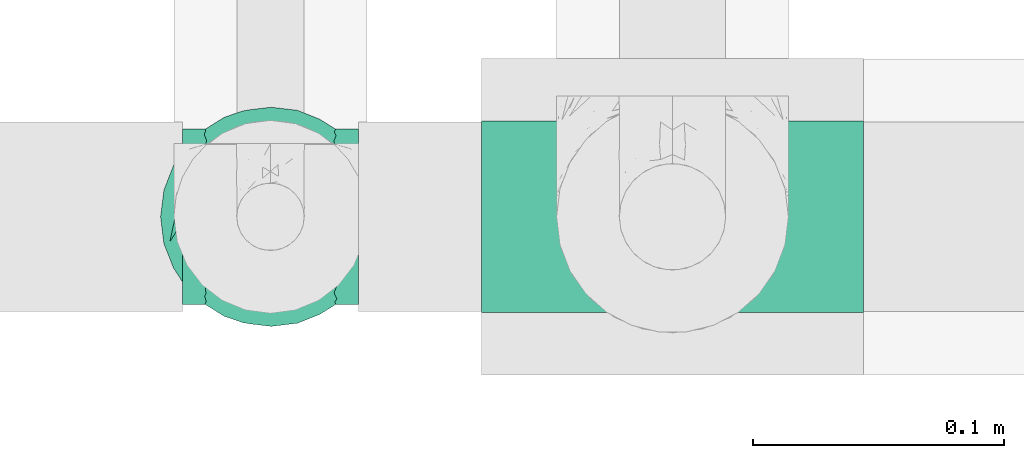
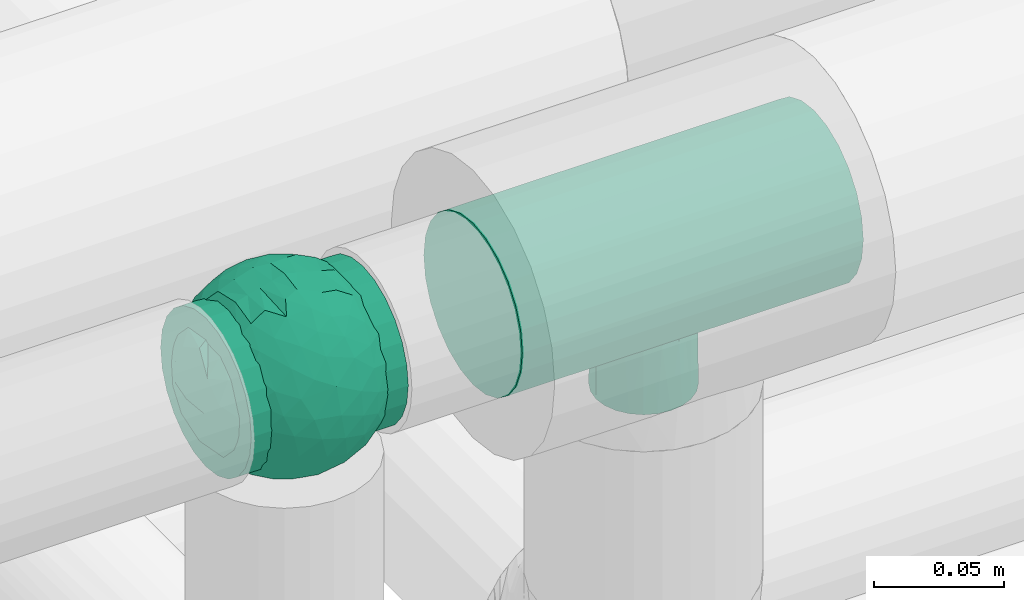
# One storey, part 690 of 827: 2 flow fittings.
"""IFC2X3 building model written with IfcOpenShell, lengths in millimetres."""

from ifc_helpers import new_model, entity, si_unit, converted_unit, derived_unit, direction, frame, origin, place, context, subcontext, project, spatial, faceted_brep, source, transform, mapped, material, material_list, type_object, type_shapes, element, save


model = new_model("IFC2X3")

# Units and contexts
model_context = context("Model", 3, precision=0.01, world=origin(), true_north=direction((6.12303176911189e-17, 1.0)))
body_context = subcontext(model_context, "Body", "Model", "MODEL_VIEW")
ifc_project = project(units=[si_unit("LENGTHUNIT", "METRE", prefix="MILLI"), si_unit("AREAUNIT", "SQUARE_METRE"), si_unit("VOLUMEUNIT", "CUBIC_METRE"), converted_unit("PLANEANGLEUNIT", "DEGREE", entity("IfcRatioMeasure", 0.0174532925199433), si_unit("PLANEANGLEUNIT", "RADIAN"), dimensions=[0, 0, 0, 0, 0, 0, 0]), si_unit("MASSUNIT", "GRAM", prefix="KILO"), derived_unit("MASSDENSITYUNIT", [(si_unit("MASSUNIT", "GRAM", prefix="KILO"), 1), (si_unit("LENGTHUNIT", "METRE"), -3)]), derived_unit("MOMENTOFINERTIAUNIT", [(si_unit("LENGTHUNIT", "METRE"), 4)]), si_unit("TIMEUNIT", "SECOND"), si_unit("FREQUENCYUNIT", "HERTZ"), si_unit("THERMODYNAMICTEMPERATUREUNIT", "DEGREE_CELSIUS"), derived_unit("THERMALTRANSMITTANCEUNIT", [(si_unit("MASSUNIT", "GRAM", prefix="KILO"), 1), (si_unit("THERMODYNAMICTEMPERATUREUNIT", "KELVIN"), -1), (si_unit("TIMEUNIT", "SECOND"), -3)]), derived_unit("VOLUMETRICFLOWRATEUNIT", [(si_unit("LENGTHUNIT", "METRE"), 3), (si_unit("TIMEUNIT", "SECOND"), -1)]), derived_unit("MASSFLOWRATEUNIT", [(si_unit("MASSUNIT", "GRAM", prefix="KILO"), 1), (si_unit("TIMEUNIT", "SECOND"), -1)]), derived_unit("ROTATIONALFREQUENCYUNIT", [(si_unit("TIMEUNIT", "SECOND"), -1)]), si_unit("ELECTRICCURRENTUNIT", "AMPERE"), si_unit("ELECTRICVOLTAGEUNIT", "VOLT"), si_unit("POWERUNIT", "WATT"), si_unit("FORCEUNIT", "NEWTON", prefix="KILO"), si_unit("ILLUMINANCEUNIT", "LUX"), si_unit("LUMINOUSFLUXUNIT", "LUMEN"), si_unit("LUMINOUSINTENSITYUNIT", "CANDELA"), derived_unit("USERDEFINED", [(si_unit("MASSUNIT", "GRAM", prefix="KILO"), -1), (si_unit("LENGTHUNIT", "METRE"), -2), (si_unit("TIMEUNIT", "SECOND"), 3), (si_unit("LUMINOUSFLUXUNIT", "LUMEN"), 1)]), derived_unit("LINEARVELOCITYUNIT", [(si_unit("LENGTHUNIT", "METRE"), 1), (si_unit("TIMEUNIT", "SECOND"), -1)]), si_unit("PRESSUREUNIT", "PASCAL"), derived_unit("USERDEFINED", [(si_unit("LENGTHUNIT", "METRE"), -2), (si_unit("MASSUNIT", "GRAM", prefix="KILO"), 1), (si_unit("TIMEUNIT", "SECOND"), -2)]), derived_unit("LINEARFORCEUNIT", [(si_unit("MASSUNIT", "GRAM", prefix="KILO"), 1), (si_unit("LENGTHUNIT", "METRE"), 1), (si_unit("TIMEUNIT", "SECOND"), -2), (si_unit("LENGTHUNIT", "METRE"), -1)]), derived_unit("PLANARFORCEUNIT", [(si_unit("MASSUNIT", "GRAM", prefix="KILO"), 1), (si_unit("LENGTHUNIT", "METRE"), 1), (si_unit("TIMEUNIT", "SECOND"), -2), (si_unit("LENGTHUNIT", "METRE"), -2)])], contexts=[model_context])

# Site, building, storey
site_placement = place(None, origin())
site = spatial("IfcSite", under=ifc_project, at=site_placement, CompositionType="ELEMENT")
building_placement = place(site_placement, origin())
building = spatial("IfcBuilding", under=site, at=building_placement, CompositionType="ELEMENT")
storey_placement = place(building_placement, frame((0.0, 0.0, 28200.0)))
storey = spatial("IfcBuildingStorey", under=building, at=storey_placement, Name="08", CompositionType="ELEMENT", Elevation=28200.0)

# Flow fittings
ifc_material_1 = material()
ifc_material_2 = material(Name="ADSK_")
ifc_material_list = material_list([ifc_material_1, ifc_material_2])
pipe_fitting_type_1 = type_object("IfcPipeFittingType", Name="ADSK_1", PredefinedType="NOTDEFINED", material=ifc_material_list)
shared_shape_1 = source(origin(), body_context, "Body", "Brep", [
    faceted_brep([(-35.0, 9.06, -33.81), (-35.0, 0.0, -35.0), (-35.0, -9.06, -33.81), (-35.0, -17.5, -30.31), (-35.0, -24.75, -24.75), (-35.0, -30.31, -17.5), (-35.0, -33.81, -9.06), (-35.0, -34.4, -4.53), (-35.0, -35.0, 0.0), (-35.0, -34.4, 4.53), (-35.0, -33.81, 9.06), (-35.0, -30.31, 17.5), (-35.0, -24.75, 24.75), (-35.0, -17.5, 30.31), (-35.0, -9.06, 33.81), (-35.0, 0.0, 35.0), (-35.0, 9.06, 33.81), (-35.0, 17.5, 30.31), (-35.0, 24.75, 24.75), (-35.0, 30.31, 17.5), (-35.0, 33.81, 9.06), (-35.0, 35.0, 0.0), (-35.0, 33.81, -9.06), (-35.0, 30.31, -17.5), (-35.0, 24.75, -24.75), (-35.0, 17.5, -30.31), (35.0, 33.81, -9.06), (35.0, 35.0, 0.0), (35.0, 33.81, 9.06), (35.0, 30.31, 17.5), (35.0, 24.75, 24.75), (35.0, 17.5, 30.31), (35.0, 9.06, 33.81), (35.0, 0.0, 35.0), (35.0, -9.06, 33.81), (35.0, -17.5, 30.31), (35.0, -24.75, 24.75), (35.0, -30.31, 17.5), (35.0, -33.81, 9.06), (35.0, -34.4, 4.53), (35.0, -35.0, 0.0), (35.0, -34.4, -4.53), (35.0, -33.81, -9.06), (35.0, -30.31, -17.5), (35.0, -24.75, -24.75), (35.0, -17.5, -30.31), (35.0, -9.06, -33.81), (35.0, 0.0, -35.0), (35.0, 9.06, -33.81), (35.0, 17.5, -30.31), (35.0, 24.75, -24.75), (35.0, 30.31, -17.5), (12.5, -35.0, 0.0), (11.74, -34.73, 4.3), (9.57, -34.06, 8.04), (2.19, -32.76, 12.31), (6.27, -33.29, 10.81), (-9.57, -34.06, 8.04), (-11.74, -34.73, 4.3), (-12.5, -35.0, 0.0), (-6.27, -33.29, 10.81), (-2.19, -32.76, 12.31), (-11.74, -34.73, -4.3), (9.57, -34.06, -8.04), (11.74, -34.73, -4.3), (6.27, -33.29, -10.81), (2.19, -32.76, -12.31), (-2.19, -32.76, -12.31), (-6.27, -33.29, -10.81), (-9.57, -34.06, -8.04), (0.0, -40.0, -12.5), (3.24, -40.0, -12.07), (6.25, -40.0, -10.83), (8.84, -40.0, -8.84), (10.83, -40.0, -6.25), (12.07, -40.0, -3.24), (12.5, -40.0, 0.0), (12.07, -40.0, 3.24), (10.83, -40.0, 6.25), (8.84, -40.0, 8.84), (6.25, -40.0, 10.83), (3.24, -40.0, 12.07), (0.0, -40.0, 12.5), (-3.24, -40.0, 12.07), (-6.25, -40.0, 10.83), (-8.84, -40.0, 8.84), (-10.83, -40.0, 6.25), (-12.07, -40.0, 3.24), (-12.5, -40.0, 0.0), (-12.07, -40.0, -3.24), (-10.83, -40.0, -6.25), (-8.84, -40.0, -8.84), (-6.25, -40.0, -10.83), (-3.24, -40.0, -12.07)], [[[0, 1, 2, 3, 4, 5, 6, 7, 8, 9, 10, 11, 12, 13, 14, 15, 16, 17, 18, 19, 20, 21, 22, 23, 24, 25]], [[26, 27, 28, 29, 30, 31, 32, 33, 34, 35, 36, 37, 38, 39, 40, 41, 42, 43, 44, 45, 46, 47, 48, 49, 50, 51]], [[52, 40, 53]], [[54, 53, 39]], [[39, 38, 54]], [[55, 37, 11]], [[38, 55, 56]], [[55, 38, 37]], [[38, 56, 54]], [[37, 36, 12, 11]], [[57, 9, 58]], [[8, 58, 9]], [[8, 59, 58]], [[57, 10, 9]], [[60, 61, 10]], [[61, 11, 10]], [[61, 55, 11]], [[60, 10, 57]], [[53, 40, 39]], [[36, 35, 13, 12]], [[15, 14, 34, 33]], [[14, 13, 35, 34]], [[16, 15, 33, 32]], [[29, 28, 20, 19]], [[18, 17, 31, 30]], [[19, 18, 30, 29]], [[32, 31, 17, 16]], [[21, 20, 28, 27]], [[21, 27, 26, 22]], [[22, 26, 51, 23]], [[24, 23, 51, 50]], [[2, 1, 47, 46]], [[0, 25, 49, 48]], [[47, 1, 0, 48]], [[49, 25, 24, 50]], [[45, 3, 2, 46]], [[62, 8, 7]], [[45, 44, 4, 3]], [[5, 4, 44, 43]], [[63, 41, 64]], [[42, 65, 66]], [[66, 43, 42]], [[5, 43, 66]], [[41, 40, 64]], [[63, 42, 41]], [[52, 64, 40]], [[42, 63, 65]], [[5, 67, 6]], [[67, 68, 6]], [[5, 66, 67]], [[62, 7, 69]], [[7, 6, 69]], [[8, 62, 59]], [[69, 6, 68]], [[70, 71, 72, 73, 74, 75, 76, 77, 78, 79, 80, 81, 82, 83, 84, 85, 86, 87, 88, 89, 90, 91, 92, 93]], [[59, 88, 87]], [[58, 86, 85]], [[87, 86, 59]], [[85, 84, 58]], [[59, 86, 58]], [[57, 58, 83]], [[61, 60, 56]], [[57, 54, 60]], [[83, 82, 57]], [[84, 83, 58]], [[54, 82, 81]], [[80, 53, 81]], [[53, 79, 78]], [[80, 79, 53]], [[52, 78, 77]], [[56, 55, 61]], [[54, 56, 60]], [[78, 52, 53]], [[53, 54, 81]], [[52, 77, 76]], [[57, 82, 54]], [[76, 75, 52]], [[73, 72, 64]], [[74, 73, 64]], [[75, 74, 52]], [[52, 74, 64]], [[63, 64, 71]], [[66, 65, 67]], [[63, 68, 65]], [[71, 70, 63]], [[72, 71, 64]], [[93, 92, 62]], [[70, 93, 69]], [[90, 89, 59]], [[91, 90, 62]], [[92, 91, 62]], [[68, 67, 65]], [[69, 68, 63]], [[90, 59, 62]], [[62, 69, 93]], [[59, 89, 88]], [[63, 70, 69]]]),
    faceted_brep([(40.99, -9.07, -12.32), (38.16, -18.39, -10.93), (36.84, -12.08, -20.28), (-10.94, -40.82, 0.0), (-15.58, -39.11, -11.91), (-9.92, -38.23, -18.83), (-21.96, -6.8, -37.22), (-28.12, 0.0, -33.51), (-18.49, 2.46, -39.57), (7.18, -35.67, -24.29), (15.31, -38.73, -13.42), (8.77, -40.44, -14.19), (42.03, 0.03, -12.13), (40.09, 14.36, -10.04), (40.82, 10.94, 0.0), (23.53, 13.3, -34.4), (12.46, 12.13, -40.15), (17.01, 22.71, -33.3), (33.97, -22.81, -15.49), (33.89, -25.88, 0.0), (-17.56, -33.17, -22.48), (-9.73, -30.72, -29.59), (32.82, 10.98, -26.77), (35.78, 20.39, -14.77), (39.41, 6.34, -17.91), (-6.73, 41.38, -12.52), (-10.94, 40.82, 0.0), (-5.47, 42.28, 0.0), (-39.41, -6.34, -17.91), (-34.66, -3.23, -26.5), (-35.7, -17.2, -18.54), (-40.84, 8.27, -13.33), (-40.82, 10.94, 0.0), (-39.08, 16.52, -10.68), (26.2, -22.53, -26.83), (19.73, -22.3, -32.05), (18.8, -14.77, -36.64), (-40.09, -14.36, -10.04), (-42.42, 0.57, -10.68), (-38.6, 2.92, -20.39), (-33.71, 5.81, -27.28), (-35.11, 22.36, -13.46), (-36.84, 12.08, -20.28), (-7.82, 5.75, -42.66), (-4.31, 16.52, -40.28), (2.55, 8.59, -42.82), (-28.09, 28.94, -16.95), (-22.22, 29.25, -23.76), (-22.19, 21.47, -31.0), (-15.79, 13.61, -38.47), (-25.69, 11.2, -33.6), (-34.44, -24.53, -11.23), (-28.84, -30.19, -13.07), (-29.88, -29.88, 0.0), (-30.32, -11.15, -29.5), (-30.71, 19.03, -24.67), (-29.88, 29.88, 0.0), (-21.87, 37.89, 0.0), (-12.26, 23.64, -34.71), (-24.05, -29.02, -22.21), (-22.18, -35.56, -12.55), (-15.83, -24.35, -32.72), (5.66, 19.83, -38.58), (10.82, 1.29, -42.37), (19.64, -4.55, -38.83), (10.45, -9.76, -41.35), (5.47, 42.28, 0.0), (10.94, 40.82, 0.0), (8.45, 41.16, -12.17), (21.88, 37.89, 0.0), (28.41, 30.93, -12.26), (22.11, 34.85, -14.53), (27.19, -11.68, -32.22), (-10.91, -4.19, -42.16), (-0.38, -15.53, -40.9), (-15.09, -13.39, -38.82), (38.72, -2.98, -20.15), (33.54, -5.5, -27.55), (35.26, 2.9, -25.74), (0.73, -39.14, -19.53), (-37.89, 21.87, 0.0), (-33.89, 25.88, 0.0), (14.01, 38.49, -15.38), (15.74, 32.52, -24.68), (5.47, -42.28, 0.0), (-0.33, -42.57, -10.07), (8.2, 28.42, -32.24), (7.65, 35.47, -24.45), (-22.26, 35.43, -12.78), (-16.78, 34.37, -21.23), (-1.21, 33.73, -27.84), (0.73, 39.14, -19.53), (16.41, 39.35, 0.0), (-6.64, -41.44, -12.35), (10.46, -22.3, -36.16), (-1.67, -26.4, -34.84), (-1.24, -33.73, -27.84), (16.41, -39.35, 0.0), (22.1, -34.75, -14.77), (21.88, -37.89, 0.0), (-16.41, 39.35, 0.0), (-15.58, 39.13, -11.84), (-8.82, 37.78, -20.23), (-9.77, 32.04, -28.15), (-23.41, -16.43, -33.11), (0.25, -3.35, -43.62), (39.35, -16.41, 0.0), (28.12, 0.0, -33.51), (29.88, -29.88, 0.0), (28.41, -30.93, -12.26), (32.42, -13.09, -26.29), (-1.67, 26.4, -34.84), (22.5, 28.09, -24.87), (28.62, 22.02, -24.7), (19.21, 5.23, -38.96), (29.88, 29.88, 0.0), (33.89, 25.88, 0.0), (37.89, 21.87, 0.0), (-0.33, 42.57, -10.07), (0.0, 43.75, 0.0), (-8.6, -19.79, -38.06), (9.0, -29.66, -30.88), (15.05, -33.47, -23.82), (21.12, -28.8, -25.27), (-28.7, -22.0, -24.62), (-33.89, -25.88, 0.0), (-43.75, 0.0, 0.0), (-40.82, -10.94, 0.0), (-37.89, -21.88, 0.0), (0.0, -43.75, 0.0), (-5.47, -42.28, 0.0), (-21.87, -37.89, 0.0), (-16.41, -39.35, 0.0), (10.94, -40.82, 0.0), (40.82, -10.94, 0.0), (39.35, 16.41, 0.0), (43.75, 0.0, 0.0), (37.89, -21.88, 0.0), (-35.11, -22.36, 13.46), (-36.84, -12.08, 20.28), (-39.08, -16.52, 10.68), (-15.58, 39.11, 11.91), (-9.92, 38.23, 18.83), (-21.96, 6.8, 37.22), (-28.12, 0.0, 33.51), (-18.49, -2.46, 39.57), (-34.66, 3.23, 26.5), (-38.6, -2.92, 20.39), (-33.71, -5.81, 27.28), (-40.09, 14.36, 10.04), (-42.42, -0.57, 10.68), (-39.41, 6.34, 17.91), (-34.44, 24.53, 11.23), (-28.84, 30.19, 13.07), (33.97, 22.81, 15.49), (38.16, 18.39, 10.93), (-17.56, 33.17, 22.48), (-9.73, 30.72, 29.59), (-35.7, 17.2, 18.54), (-6.73, -41.38, 12.52), (39.41, -6.34, 17.91), (32.82, -10.98, 26.77), (35.78, -20.39, 14.77), (-40.84, -8.27, 13.33), (26.2, 22.53, 26.83), (19.73, 22.3, 32.05), (18.8, 14.77, 36.64), (42.03, -0.03, 12.13), (40.09, -14.36, 10.04), (7.18, 35.67, 24.29), (15.31, 38.73, 13.42), (8.77, 40.44, 14.19), (40.99, 9.07, 12.32), (36.84, 12.08, 20.28), (-7.82, -5.75, 42.66), (-4.31, -16.52, 40.28), (2.55, -8.59, 42.82), (-28.09, -28.94, 16.95), (-22.22, -29.25, 23.76), (-22.19, -21.47, 31.0), (-15.79, -13.61, 38.47), (-25.69, -11.2, 33.6), (12.46, -12.13, 40.15), (17.01, -22.71, 33.3), (23.53, -13.3, 34.4), (-30.32, 11.15, 29.5), (-30.71, -19.03, 24.67), (-12.26, -23.64, 34.71), (-24.05, 29.02, 22.21), (-22.18, 35.56, 12.55), (-15.83, 24.35, 32.72), (5.66, -19.83, 38.58), (10.82, -1.29, 42.37), (19.64, 4.55, 38.83), (10.45, 9.76, 41.35), (8.45, -41.16, 12.17), (28.41, -30.93, 12.26), (22.11, -34.85, 14.53), (27.19, 11.68, 32.22), (-10.91, 4.19, 42.16), (-0.38, 15.53, 40.9), (-15.09, 13.39, 38.82), (38.72, 2.98, 20.15), (33.54, 5.5, 27.55), (35.26, -2.9, 25.74), (0.73, 39.14, 19.53), (14.01, -38.49, 15.38), (15.74, -32.52, 24.68), (-0.33, 42.57, 10.07), (8.2, -28.42, 32.24), (7.65, -35.47, 24.45), (-22.26, -35.43, 12.78), (-16.78, -34.37, 21.23), (-1.21, -33.73, 27.84), (0.73, -39.14, 19.53), (-6.64, 41.44, 12.35), (10.46, 22.3, 36.16), (-1.67, 26.4, 34.84), (-1.24, 33.73, 27.84), (22.1, 34.75, 14.77), (-15.58, -39.13, 11.84), (-8.82, -37.78, 20.23), (-9.77, -32.04, 28.14), (-23.41, 16.43, 33.11), (0.25, 3.35, 43.62), (28.12, 0.0, 33.51), (28.41, 30.93, 12.26), (32.42, 13.09, 26.29), (-1.67, -26.4, 34.84), (22.5, -28.09, 24.87), (28.62, -22.02, 24.7), (19.21, -5.23, 38.96), (-0.33, -42.57, 10.07), (-8.6, 19.79, 38.06), (9.0, 29.66, 30.88), (15.05, 33.47, 23.82), (21.12, 28.8, 25.27), (-28.7, 22.0, 24.62)], [[[0, 1, 2]], [[3, 4, 5]], [[6, 7, 8]], [[9, 10, 11]], [[12, 13, 14]], [[15, 16, 17]], [[18, 1, 19]], [[20, 21, 5]], [[22, 23, 24]], [[25, 26, 27]], [[28, 29, 30]], [[31, 32, 33]], [[34, 35, 36]], [[37, 38, 28]], [[29, 39, 40]], [[33, 41, 42]], [[43, 44, 45]], [[46, 47, 48]], [[49, 8, 50]], [[51, 52, 53]], [[7, 6, 54]], [[55, 50, 40]], [[46, 56, 57]], [[49, 58, 44]], [[46, 55, 41]], [[52, 59, 60]], [[49, 44, 43]], [[59, 61, 20]], [[62, 16, 45]], [[63, 64, 65]], [[66, 67, 68]], [[69, 70, 71]], [[72, 36, 64]], [[73, 74, 75]], [[76, 77, 78]], [[9, 11, 79]], [[41, 80, 81, 56]], [[82, 71, 83]], [[11, 84, 85]], [[86, 87, 83]], [[88, 89, 47]], [[87, 82, 83]], [[87, 90, 91]], [[71, 82, 92]], [[17, 16, 62]], [[79, 85, 93]], [[74, 94, 95]], [[9, 79, 96]], [[97, 98, 99]], [[100, 26, 101]], [[55, 46, 48]], [[90, 102, 91]], [[102, 103, 89]], [[104, 61, 59]], [[20, 61, 21]], [[8, 7, 50]], [[105, 43, 45]], [[0, 106, 1]], [[107, 15, 22]], [[108, 109, 18]], [[110, 72, 77]], [[50, 55, 48]], [[109, 99, 98]], [[41, 55, 42]], [[49, 50, 48]], [[50, 7, 40]], [[58, 49, 48]], [[49, 43, 8]], [[73, 8, 43]], [[8, 73, 6]], [[58, 48, 47]], [[58, 111, 44]], [[62, 44, 111]], [[44, 62, 45]], [[39, 38, 31]], [[46, 41, 56]], [[111, 86, 62]], [[62, 86, 17]], [[112, 83, 71]], [[15, 17, 113]], [[90, 87, 86]], [[17, 86, 83]], [[22, 15, 113]], [[107, 64, 114]], [[23, 113, 70]], [[24, 76, 78]], [[113, 23, 22]], [[23, 115, 116, 117]], [[13, 12, 24]], [[90, 86, 111]], [[87, 91, 68]], [[68, 118, 66]], [[69, 71, 92]], [[82, 67, 92]], [[70, 69, 115]], [[83, 112, 17]], [[23, 70, 115]], [[112, 70, 113]], [[103, 111, 58]], [[82, 68, 67]], [[90, 103, 102]], [[101, 102, 89]], [[27, 119, 118]], [[27, 118, 25]], [[16, 63, 45]], [[45, 63, 105]], [[74, 105, 65]], [[73, 75, 6]], [[16, 15, 114]], [[105, 63, 65]], [[94, 74, 65]], [[21, 120, 95]], [[65, 64, 36]], [[121, 122, 9]], [[114, 64, 63]], [[72, 64, 107]], [[72, 107, 77]], [[35, 34, 123]], [[34, 36, 72]], [[94, 65, 36]], [[66, 118, 119]], [[25, 91, 102]], [[87, 68, 82]], [[118, 68, 91]], [[70, 112, 71]], [[113, 17, 112]], [[43, 105, 73]], [[74, 73, 105]], [[16, 114, 63]], [[107, 114, 15]], [[91, 25, 118]], [[25, 102, 101]], [[75, 104, 6]], [[6, 104, 54]], [[30, 54, 124]], [[29, 7, 54]], [[53, 125, 51]], [[40, 42, 55]], [[104, 75, 61]], [[37, 30, 51]], [[54, 104, 124]], [[120, 61, 75]], [[61, 120, 21]], [[111, 103, 90]], [[58, 89, 103]], [[30, 29, 54]], [[39, 29, 28]], [[125, 37, 51]], [[40, 39, 42]], [[38, 39, 28]], [[41, 33, 80]], [[32, 38, 126]], [[127, 37, 128]], [[127, 126, 38]], [[7, 29, 40]], [[95, 96, 21]], [[21, 96, 5]], [[85, 129, 130]], [[131, 60, 132]], [[94, 121, 95]], [[5, 96, 79]], [[96, 95, 121]], [[5, 93, 3]], [[9, 122, 10]], [[97, 10, 98]], [[129, 85, 84]], [[11, 133, 84]], [[121, 9, 96]], [[121, 94, 35]], [[122, 123, 98]], [[133, 11, 10]], [[99, 109, 108]], [[123, 109, 98]], [[72, 110, 34]], [[34, 18, 109]], [[1, 18, 2]], [[98, 10, 122]], [[97, 133, 10]], [[93, 85, 130]], [[85, 79, 11]], [[3, 93, 130]], [[79, 93, 5]], [[42, 39, 31]], [[32, 80, 33]], [[123, 122, 121]], [[109, 123, 34]], [[121, 35, 123]], [[94, 36, 35]], [[38, 37, 127]], [[30, 37, 28]], [[30, 124, 51]], [[128, 37, 125]], [[52, 51, 124]], [[59, 52, 124]], [[131, 53, 52]], [[59, 124, 104]], [[59, 20, 60]], [[3, 132, 4]], [[60, 20, 4]], [[52, 60, 131]], [[24, 23, 13]], [[19, 108, 18]], [[12, 134, 0]], [[2, 76, 0]], [[0, 76, 12]], [[77, 76, 2]], [[12, 76, 24]], [[77, 2, 110]], [[78, 107, 22]], [[13, 117, 135, 14]], [[134, 12, 136]], [[107, 78, 77]], [[136, 12, 14]], [[24, 78, 22]], [[1, 137, 19]], [[106, 0, 134]], [[106, 137, 1]], [[23, 117, 13]], [[2, 18, 110]], [[34, 110, 18]], [[60, 4, 132]], [[20, 5, 4]], [[32, 31, 38]], [[42, 31, 33]], [[100, 101, 88]], [[58, 47, 89]], [[88, 46, 57]], [[46, 88, 47]], [[100, 88, 57]], [[101, 26, 25]], [[88, 101, 89]], [[75, 74, 120]], [[95, 120, 74]], [[138, 139, 140]], [[26, 141, 142]], [[143, 144, 145]], [[146, 147, 148]], [[149, 150, 151]], [[56, 152, 153]], [[154, 155, 116]], [[156, 157, 142]], [[146, 158, 151]], [[159, 3, 130]], [[160, 161, 162]], [[163, 127, 140]], [[164, 165, 166]], [[167, 168, 134]], [[169, 170, 171]], [[172, 155, 173]], [[174, 175, 176]], [[177, 178, 179]], [[180, 145, 181]], [[182, 183, 184]], [[144, 143, 185]], [[186, 181, 148]], [[177, 53, 131]], [[180, 187, 175]], [[177, 186, 138]], [[153, 188, 189]], [[180, 175, 174]], [[188, 190, 156]], [[191, 182, 176]], [[192, 193, 194]], [[84, 133, 195]], [[99, 196, 197]], [[198, 166, 193]], [[199, 200, 201]], [[202, 203, 204]], [[169, 171, 205]], [[138, 128, 125, 53]], [[206, 197, 207]], [[171, 66, 208]], [[209, 210, 207]], [[211, 212, 178]], [[210, 206, 207]], [[210, 213, 214]], [[197, 206, 97]], [[183, 182, 191]], [[205, 208, 215]], [[200, 216, 217]], [[169, 205, 218]], [[92, 219, 69]], [[132, 3, 220]], [[186, 177, 179]], [[213, 221, 214]], [[221, 222, 212]], [[223, 190, 188]], [[156, 190, 157]], [[145, 144, 181]], [[224, 174, 176]], [[172, 135, 155]], [[225, 184, 161]], [[115, 226, 154]], [[227, 198, 203]], [[181, 186, 179]], [[226, 69, 219]], [[138, 186, 139]], [[180, 181, 179]], [[181, 144, 148]], [[187, 180, 179]], [[180, 174, 145]], [[199, 145, 174]], [[145, 199, 143]], [[187, 179, 178]], [[187, 228, 175]], [[191, 175, 228]], [[175, 191, 176]], [[147, 150, 163]], [[177, 138, 53]], [[228, 209, 191]], [[191, 209, 183]], [[229, 207, 197]], [[184, 183, 230]], [[213, 210, 209]], [[183, 209, 207]], [[161, 184, 230]], [[225, 193, 231]], [[162, 230, 196]], [[160, 202, 204]], [[230, 162, 161]], [[162, 108, 19, 137]], [[168, 167, 160]], [[213, 209, 228]], [[210, 214, 195]], [[195, 232, 84]], [[99, 197, 97]], [[206, 133, 97]], [[196, 99, 108]], [[207, 229, 183]], [[162, 196, 108]], [[229, 196, 230]], [[222, 228, 187]], [[206, 195, 133]], [[213, 222, 221]], [[220, 221, 212]], [[130, 129, 232]], [[130, 232, 159]], [[182, 192, 176]], [[176, 192, 224]], [[200, 224, 194]], [[199, 201, 143]], [[182, 184, 231]], [[224, 192, 194]], [[216, 200, 194]], [[157, 233, 217]], [[194, 193, 166]], [[234, 235, 169]], [[231, 193, 192]], [[198, 193, 225]], [[198, 225, 203]], [[165, 164, 236]], [[164, 166, 198]], [[216, 194, 166]], [[84, 232, 129]], [[159, 214, 221]], [[210, 195, 206]], [[232, 195, 214]], [[196, 229, 197]], [[230, 183, 229]], [[174, 224, 199]], [[200, 199, 224]], [[182, 231, 192]], [[225, 231, 184]], [[214, 159, 232]], [[159, 221, 220]], [[201, 223, 143]], [[143, 223, 185]], [[158, 185, 237]], [[146, 144, 185]], [[56, 81, 152]], [[148, 139, 186]], [[223, 201, 190]], [[149, 158, 152]], [[185, 223, 237]], [[233, 190, 201]], [[190, 233, 157]], [[228, 222, 213]], [[187, 212, 222]], [[158, 146, 185]], [[147, 146, 151]], [[81, 149, 152]], [[148, 147, 139]], [[150, 147, 151]], [[138, 140, 128]], [[127, 150, 126]], [[32, 149, 80]], [[32, 126, 150]], [[144, 146, 148]], [[217, 218, 157]], [[157, 218, 142]], [[208, 119, 27]], [[57, 189, 100]], [[216, 234, 217]], [[142, 218, 205]], [[218, 217, 234]], [[142, 215, 26]], [[169, 235, 170]], [[92, 170, 219]], [[119, 208, 66]], [[171, 67, 66]], [[234, 169, 218]], [[234, 216, 165]], [[235, 236, 219]], [[67, 171, 170]], [[69, 226, 115]], [[236, 226, 219]], [[198, 227, 164]], [[164, 154, 226]], [[155, 154, 173]], [[219, 170, 235]], [[92, 67, 170]], [[215, 208, 27]], [[208, 205, 171]], [[26, 215, 27]], [[205, 215, 142]], [[139, 147, 163]], [[127, 128, 140]], [[236, 235, 234]], [[226, 236, 164]], [[234, 165, 236]], [[216, 166, 165]], [[150, 149, 32]], [[158, 149, 151]], [[158, 237, 152]], [[80, 149, 81]], [[153, 152, 237]], [[188, 153, 237]], [[57, 56, 153]], [[188, 237, 223]], [[188, 156, 189]], [[26, 100, 141]], [[189, 156, 141]], [[153, 189, 57]], [[160, 162, 168]], [[116, 115, 154]], [[167, 14, 172]], [[173, 202, 172]], [[172, 202, 167]], [[203, 202, 173]], [[167, 202, 160]], [[203, 173, 227]], [[204, 225, 161]], [[168, 137, 106, 134]], [[14, 167, 136]], [[225, 204, 203]], [[136, 167, 134]], [[160, 204, 161]], [[155, 117, 116]], [[135, 172, 14]], [[135, 117, 155]], [[162, 137, 168]], [[173, 154, 227]], [[164, 227, 154]], [[189, 141, 100]], [[156, 142, 141]], [[127, 163, 150]], [[139, 163, 140]], [[132, 220, 211]], [[187, 178, 212]], [[211, 177, 131]], [[177, 211, 178]], [[132, 211, 131]], [[220, 3, 159]], [[211, 220, 212]], [[201, 200, 233]], [[217, 233, 200]]]),
])
type_shapes(pipe_fitting_type_1, [shared_shape_1])
flow_fitting_1_placement = place(storey_placement, frame((53909.79, 15922.38, 2700.0), z_axis=(0.0, -1.0, 0.0), x_axis=(1.0, 0.0, 0.0)))
element("IfcFlowFitting", 1, at=flow_fitting_1_placement, inside=storey, type_object=pipe_fitting_type_1, material=ifc_material_list, Name="ADSK_1", ObjectType="ADSK_1", context=body_context, shape_type="MappedRepresentation", body=[
    mapped(shared_shape_1, transform((0.0, 0.0, 0.0), scale=1.0)),
])
pipe_fitting_type_2 = type_object("IfcPipeFittingType", Name="ADSK_1", PredefinedType="NOTDEFINED", material=ifc_material_1)
shared_shape_2 = source(origin(), body_context, "Body", "Brep", [
    faceted_brep([(-76.0, 9.85, -36.75), (-76.0, 0.0, -38.05), (-76.0, -9.85, -36.75), (-76.0, -19.03, -32.95), (-76.0, -26.91, -26.91), (-76.0, -32.95, -19.03), (-76.0, -36.75, -9.85), (-76.0, -38.05, 0.0), (-76.0, -36.75, 9.85), (-76.0, -32.95, 19.02), (-76.0, -26.91, 26.91), (-76.0, -19.03, 32.95), (-76.0, -9.85, 36.75), (-76.0, 0.0, 38.05), (-76.0, 9.85, 36.75), (-76.0, 19.02, 32.95), (-76.0, 26.91, 26.91), (-76.0, 32.95, 19.02), (-76.0, 36.75, 9.85), (-76.0, 38.05, 0.0), (-76.0, 36.75, -9.85), (-76.0, 32.95, -19.03), (-76.0, 26.91, -26.91), (-76.0, 19.02, -32.95), (76.0, 26.91, -26.91), (76.0, 32.95, -19.03), (76.0, 36.75, -9.85), (76.0, 38.05, 0.0), (76.0, 36.75, 9.85), (76.0, 32.95, 19.02), (76.0, 26.91, 26.91), (76.0, 19.02, 32.95), (76.0, 9.85, 36.75), (76.0, 0.0, 38.05), (76.0, -9.85, 36.75), (76.0, -19.03, 32.95), (76.0, -26.91, 26.91), (76.0, -32.95, 19.02), (76.0, -36.75, 9.85), (76.0, -38.05, 0.0), (76.0, -36.75, -9.85), (76.0, -32.95, -19.03), (76.0, -26.91, -26.91), (76.0, -19.03, -32.95), (76.0, -9.85, -36.75), (76.0, 0.0, -38.05), (76.0, 9.85, -36.75), (76.0, 19.02, -32.95), (19.88, -37.33, 7.37), (20.54, -37.69, 3.68), (21.2, -38.05, 0.0), (16.2, -35.51, 13.68), (3.75, -31.82, 20.87), (10.67, -33.35, 18.32), (7.21, -32.58, 19.59), (-21.2, -38.05, 0.0), (-20.54, -37.69, 3.68), (-19.88, -37.33, 7.37), (-16.2, -35.51, 13.67), (-10.67, -33.35, 18.32), (-7.22, -32.59, 19.59), (-3.76, -31.82, 20.86), (0.0, -31.82, 20.86), (3.75, -31.82, -20.87), (10.67, -33.35, -18.32), (7.21, -32.58, -19.59), (16.2, -35.51, -13.68), (19.88, -37.33, -7.37), (20.54, -37.69, -3.68), (-3.76, -31.82, -20.86), (-7.22, -32.59, -19.59), (-10.67, -33.35, -18.32), (-16.2, -35.51, -13.67), (0.0, -31.82, -20.86), (-19.88, -37.33, -7.37), (-20.54, -37.69, -3.68), (0.0, -64.0, -21.2), (5.49, -64.0, -20.48), (10.6, -64.0, -18.36), (14.99, -64.0, -14.99), (18.36, -64.0, -10.6), (20.48, -64.0, -5.49), (21.2, -64.0, 0.0), (20.48, -64.0, 5.49), (18.36, -64.0, 10.6), (14.99, -64.0, 14.99), (10.6, -64.0, 18.36), (5.49, -64.0, 20.48), (0.0, -64.0, 21.2), (-5.49, -64.0, 20.48), (-10.6, -64.0, 18.36), (-14.99, -64.0, 14.99), (-18.36, -64.0, 10.6), (-20.48, -64.0, 5.49), (-21.2, -64.0, 0.0), (-20.48, -64.0, -5.49), (-18.36, -64.0, -10.6), (-14.99, -64.0, -14.99), (-10.6, -64.0, -18.36), (-5.49, -64.0, -20.48)], [[[0, 1, 2, 3, 4, 5, 6, 7, 8, 9, 10, 11, 12, 13, 14, 15, 16, 17, 18, 19, 20, 21, 22, 23]], [[24, 25, 26, 27, 28, 29, 30, 31, 32, 33, 34, 35, 36, 37, 38, 39, 40, 41, 42, 43, 44, 45, 46, 47]], [[39, 38, 48]], [[39, 48, 49, 50]], [[38, 51, 48]], [[37, 36, 52]], [[53, 51, 37]], [[37, 52, 54, 53]], [[36, 10, 52]], [[37, 51, 38]], [[7, 55, 56, 57]], [[8, 7, 57]], [[57, 58, 8]], [[9, 59, 60, 61]], [[59, 9, 58]], [[9, 61, 10]], [[58, 9, 8]], [[10, 61, 62, 52]], [[36, 35, 11, 10]], [[13, 12, 34, 33]], [[12, 11, 35, 34]], [[14, 13, 33, 32]], [[29, 28, 18, 17]], [[16, 15, 31, 30]], [[17, 16, 30, 29]], [[32, 31, 15, 14]], [[19, 18, 28, 27]], [[26, 25, 21, 20]], [[25, 24, 22, 21]], [[27, 26, 20, 19]], [[45, 44, 2, 1]], [[0, 23, 47, 46]], [[1, 0, 46, 45]], [[24, 47, 23, 22]], [[3, 2, 44, 43]], [[43, 42, 4, 3]], [[42, 41, 63]], [[41, 64, 65, 63]], [[41, 66, 64]], [[42, 63, 4]], [[40, 39, 67]], [[67, 66, 40]], [[39, 50, 68, 67]], [[40, 66, 41]], [[5, 69, 70, 71]], [[5, 4, 69]], [[71, 72, 5]], [[4, 63, 73, 69]], [[72, 74, 6]], [[74, 7, 6]], [[7, 74, 75, 55]], [[72, 6, 5]], [[76, 77, 78, 79, 80, 81, 82, 83, 84, 85, 86, 87, 88, 89, 90, 91, 92, 93, 94, 95, 96, 97, 98, 99]], [[93, 56, 94]], [[88, 61, 89]], [[60, 90, 89]], [[60, 59, 90]], [[93, 57, 56]], [[57, 93, 92]], [[49, 48, 83]], [[58, 92, 91]], [[56, 55, 94]], [[57, 92, 58]], [[86, 54, 87]], [[59, 58, 91]], [[89, 61, 60]], [[59, 91, 90]], [[88, 52, 62, 61]], [[86, 53, 54]], [[85, 53, 86]], [[48, 84, 83]], [[85, 84, 51]], [[52, 88, 87]], [[54, 52, 87]], [[53, 85, 51]], [[51, 84, 48]], [[82, 49, 83]], [[49, 82, 50]], [[81, 68, 82]], [[66, 80, 79]], [[75, 94, 55]], [[81, 67, 68]], [[80, 67, 81]], [[78, 64, 79]], [[68, 50, 82]], [[67, 80, 66]], [[77, 63, 65]], [[64, 66, 79]], [[76, 69, 73, 63]], [[98, 70, 99]], [[65, 64, 78]], [[98, 71, 70]], [[76, 63, 77]], [[75, 74, 95]], [[97, 71, 98]], [[74, 96, 95]], [[97, 96, 72]], [[69, 76, 99]], [[70, 69, 99]], [[71, 97, 72]], [[72, 96, 74]], [[94, 75, 95]], [[65, 78, 77]]]),
])
type_shapes(pipe_fitting_type_2, [shared_shape_2])
flow_fitting_2_placement = place(storey_placement, frame((54069.79, 15922.38, 2700.0), z_axis=(0.0, -1.0, 0.0), x_axis=(1.0, 0.0, 0.0)))
element("IfcFlowFitting", 2, at=flow_fitting_2_placement, inside=storey, type_object=pipe_fitting_type_2, material=ifc_material_1, Name="ADSK_1", ObjectType="ADSK_1", context=body_context, shape_type="MappedRepresentation", body=[
    mapped(shared_shape_2, transform((0.0, 0.0, 0.0), scale=1.0)),
])

save(model, "model.ifc")
